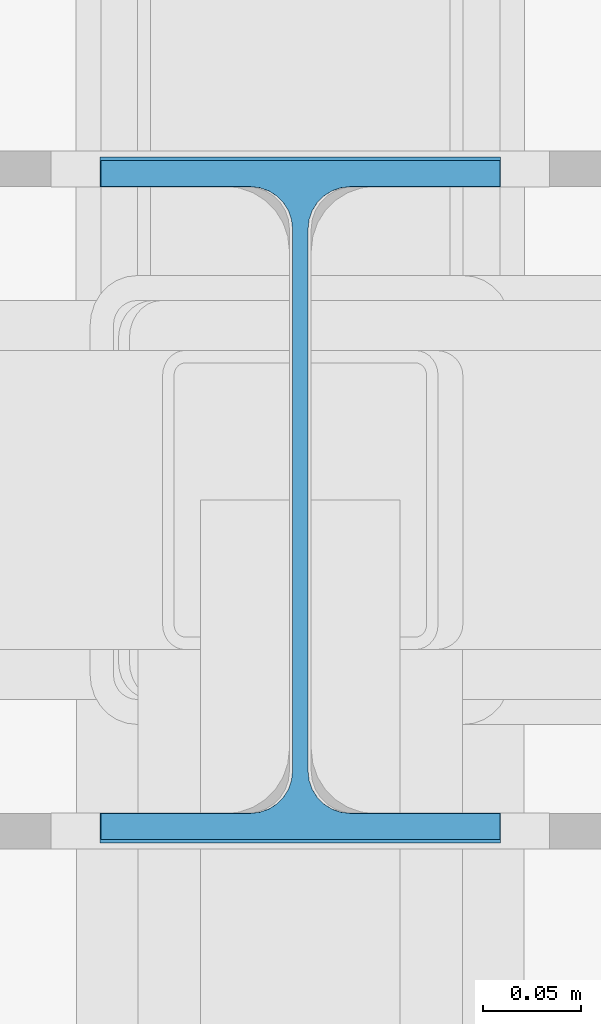
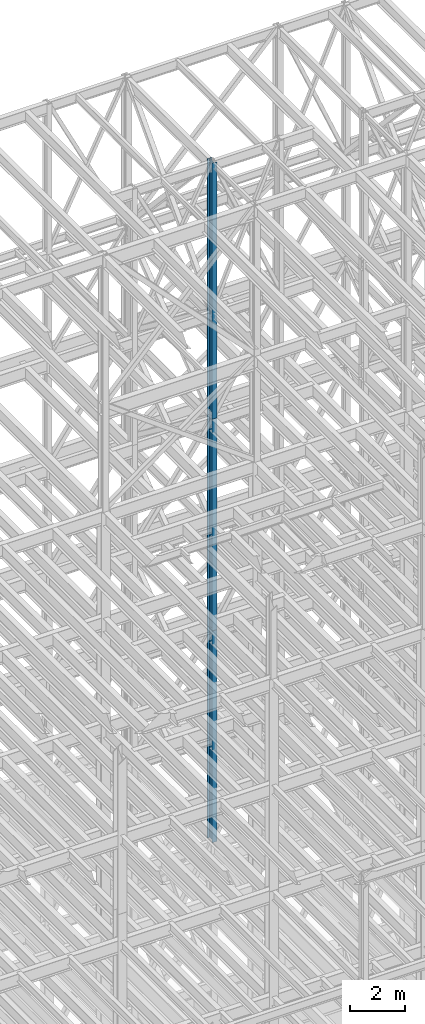
# One storey, part 44 of 150: 3 columns.
"""IFC2X3 building model written with IfcOpenShell, lengths in millimetres."""

import ifcopenshell
import ifcopenshell.guid

model = None  # the IFC model being written
_history = None  # IfcOwnerHistory: only IFC2X3 demands one
_inside = {}  # id of a spatial element -> (the spatial element, [elements in it])
_under = {}  # id of a project, library or spatial element -> (it, [spatial elements below it])
_declared = {}  # id of a project -> (the project, [libraries it declares])
_typed = {}  # id of a type object -> (the type object, [elements of that type])
_made_of = {}  # id of a material, layer set ... -> (it, [elements and type objects made of it])


def new_model(schema):
    """Start an empty IFC model of exactly this schema.

    Asked for "IFC4X3", IfcOpenShell would pick the latest addendum, in which some entities
    have other attributes; the version numbers below select the first issue.
    IFC2X3 requires an IfcOwnerHistory on every rooted entity: one is made here for all.
    """
    global model, _history
    if schema == "IFC4X3":
        model = ifcopenshell.file(schema_version=(4, 3, 0, 0))
    else:
        model = ifcopenshell.file(schema=schema)
    _inside.clear()
    _under.clear()
    _declared.clear()
    _typed.clear()
    _made_of.clear()
    _history = None
    if model.schema == "IFC2X3":
        org = make("IfcOrganization", Name="unknown")
        user = make(
            "IfcPersonAndOrganization",
            ThePerson=make("IfcPerson", FamilyName="unknown"),
            TheOrganization=org,
        )
        app = make(
            "IfcApplication",
            ApplicationDeveloper=org,
            Version="unknown",
            ApplicationFullName="unknown",
            ApplicationIdentifier="unknown",
        )
        _history = make(
            "IfcOwnerHistory",
            OwningUser=user,
            OwningApplication=app,
            ChangeAction="ADDED",
            CreationDate=0,
        )
    return model


def make(cls, **values):
    """One entity of the class cls with the attributes given. An attribute that is None is left unset."""
    return model.create_entity(
        cls, **{name: value for name, value in values.items() if value is not None}
    )


def rooted(cls, **values):
    """An entity with a GlobalId (a new one), such as an element, a storey or a relation."""
    return make(cls, GlobalId=ifcopenshell.guid.new(), OwnerHistory=_history, **values)


def si_unit(unit_type, name, prefix=None):
    """IfcSIUnit, for example si_unit("LENGTHUNIT", "METRE", prefix="MILLI")."""
    return make("IfcSIUnit", UnitType=unit_type, Prefix=prefix, Name=name)


def assignment(units):
    """IfcUnitAssignment: the units of a project."""
    return None if units is None else make("IfcUnitAssignment", Units=units)


def point(xyz):
    """IfcCartesianPoint."""
    return None if xyz is None else make("IfcCartesianPoint", Coordinates=xyz)


def direction(xyz):
    """IfcDirection."""
    return None if xyz is None else make("IfcDirection", DirectionRatios=xyz)


def frame(location, z_axis=None, x_axis=None):
    """IfcAxis2Placement3D, a coordinate frame: its origin and axes. An axis left out is left unset."""
    return make(
        "IfcAxis2Placement3D",
        Location=point(location),
        Axis=direction(z_axis),
        RefDirection=direction(x_axis),
    )


def frame_2d(location, x_axis=None):
    """IfcAxis2Placement2D, a coordinate frame in the plane: its origin and x axis."""
    return make(
        "IfcAxis2Placement2D", Location=point(location), RefDirection=direction(x_axis)
    )


def origin_with_axes():
    """The frame at (0, 0, 0) with the z axis (0, 0, 1) and the x axis (1, 0, 0) written out."""
    return frame((0.0, 0.0, 0.0), z_axis=(0.0, 0.0, 1.0), x_axis=(1.0, 0.0, 0.0))


def origin_2d_with_axis():
    """The frame at (0, 0) in the plane with the x axis (1, 0) written out."""
    return frame_2d((0.0, 0.0), x_axis=(1.0, 0.0))


def place(relative_to, where):
    """IfcLocalPlacement: puts the frame where relative to a parent placement (None: the world)."""
    return make(
        "IfcLocalPlacement", PlacementRelTo=relative_to, RelativePlacement=where
    )


def context(
    kind, dimensions, precision=None, world=None, true_north=None, identifier=None
):
    """IfcGeometricRepresentationContext, for example the 3D "Model" context."""
    return make(
        "IfcGeometricRepresentationContext",
        ContextIdentifier=identifier,
        ContextType=kind,
        CoordinateSpaceDimension=dimensions,
        Precision=precision,
        WorldCoordinateSystem=world,
        TrueNorth=true_north,
    )


def subcontext(parent, identifier, kind, view, scale=None):
    """IfcGeometricRepresentationSubContext, for example "Body" below "Model"."""
    return make(
        "IfcGeometricRepresentationSubContext",
        ContextIdentifier=identifier,
        ContextType=kind,
        ParentContext=parent,
        TargetScale=scale,
        TargetView=view,
    )


def project(units=None, contexts=None):
    """IfcProject with its units and contexts."""
    return rooted(
        "IfcProject",
        Name="project",
        RepresentationContexts=contexts,
        UnitsInContext=assignment(units),
    )


def spatial(cls, under=None, at=None, **own):
    """A site, building, storey or space (cls), placed at a placement, below another one or the project."""
    s = rooted(cls, ObjectPlacement=at, **own)
    if under is not None:
        _under.setdefault(under.id(), (under, []))[1].append(s)
    return s


def profile(cls, at=None, kind="AREA", **sizes):
    """A parametric profile (cls). Its sizes go by their IFC names, for example OverallWidth=200.0."""
    return make(cls, ProfileType=kind, Position=at, **sizes)


def i_section(**sizes):
    """IfcIShapeProfileDef."""
    return profile("IfcIShapeProfileDef", **sizes)


def extrude(swept, where, along, depth):
    """IfcExtrudedAreaSolid: the profile swept, set in the frame where, extruded along a direction by depth."""
    return make(
        "IfcExtrudedAreaSolid",
        SweptArea=swept,
        Position=where,
        ExtrudedDirection=direction(along),
        Depth=depth,
    )


def shape(context_of_items, identifier, shape_type, items):
    """IfcShapeRepresentation: the items that make up one representation, for example the "Body"."""
    return make(
        "IfcShapeRepresentation",
        ContextOfItems=context_of_items,
        RepresentationIdentifier=identifier,
        RepresentationType=shape_type,
        Items=items,
    )


def material(Name=None, Category=None):
    """IfcMaterial."""
    return make("IfcMaterial", Name=Name, Category=Category)


def made_of(thing, what):
    """Note that an element or type object is made of a material, layer set ...; save() writes the relation."""
    if what is not None:
        _made_of.setdefault(what.id(), (what, []))[1].append(thing)
    return thing


def type_object(cls, material=None, **own):
    """A type object (cls), such as IfcWallType, which elements share."""
    return made_of(rooted(cls, **own), material)


def element(
    cls,
    number,
    at=None,
    inside=None,
    cuts=None,
    type_object=None,
    material=None,
    context=None,
    identifier="Body",
    shape_type=None,
    held_by="IfcProductDefinitionShape",
    body=None,
    shapes=None,
    **own,
):
    """One element of the class cls, such as IfcWall. Its Tag is "e" and its number.

    at: its placement. inside: the storey or other place that contains it. cuts: it is an
    opening in that element (IfcRelVoidsElement). A single representation is given by context,
    identifier, shape_type and body (its items); several are given by shapes. held_by: the class
    of the entity that holds the representations. save() writes the other relations.
    """
    e = rooted(cls, Tag="e%d" % number, ObjectPlacement=at, **own)
    if body is not None:
        shapes = [shape(context, identifier, shape_type, body)]
    if shapes is not None:
        e.Representation = make(held_by, Representations=shapes)
    if inside is not None:
        _inside.setdefault(inside.id(), (inside, []))[1].append(e)
    if cuts is not None:
        rooted(
            "IfcRelVoidsElement", RelatingBuildingElement=cuts, RelatedOpeningElement=e
        )
    if type_object is not None:
        _typed.setdefault(type_object.id(), (type_object, []))[1].append(e)
    return made_of(e, material)


def aggregate(whole, parts):
    """IfcRelAggregates: a whole, such as a stair, and the parts it consists of."""
    return rooted("IfcRelAggregates", RelatingObject=whole, RelatedObjects=parts)


def save(model, path):
    """Write the relations noted so far, then the file.

    IfcRelAggregates (storeys below a building ...), IfcRelContainedInSpatialStructure (elements
    in a storey), IfcRelDefinesByType, IfcRelAssociatesMaterial and IfcRelDeclares: one each for
    every whole, place, type object, material and project.
    """
    for whole, parts in _under.values():
        aggregate(whole, parts)
    for where, things in _inside.values():
        rooted(
            "IfcRelContainedInSpatialStructure",
            RelatedElements=things,
            RelatingStructure=where,
        )
    for kind, things in _typed.values():
        rooted("IfcRelDefinesByType", RelatedObjects=things, RelatingType=kind)
    for what, things in _made_of.values():
        rooted("IfcRelAssociatesMaterial", RelatedObjects=things, RelatingMaterial=what)
    for by, libraries in _declared.values():
        rooted("IfcRelDeclares", RelatingContext=by, RelatedDefinitions=libraries)
    model.write(path)


model = new_model("IFC2X3")

# Units and contexts
model_context = context("Model", 3, precision=1e-05, world=origin_with_axes())
body_context = subcontext(model_context, "Body", "Model", "MODEL_VIEW")
ifc_project = project(units=[si_unit("LENGTHUNIT", "METRE", prefix="MILLI"), si_unit("AREAUNIT", "SQUARE_METRE"), si_unit("VOLUMEUNIT", "CUBIC_METRE"), si_unit("MASSUNIT", "GRAM", prefix="KILO"), si_unit("TIMEUNIT", "SECOND"), si_unit("PLANEANGLEUNIT", "RADIAN"), si_unit("SOLIDANGLEUNIT", "STERADIAN"), si_unit("THERMODYNAMICTEMPERATUREUNIT", "DEGREE_CELSIUS"), si_unit("LUMINOUSINTENSITYUNIT", "LUMEN")], contexts=[model_context])

# Site, building, storey
site_placement = place(None, origin_with_axes())
site = spatial("IfcSite", under=ifc_project, at=site_placement, CompositionType="ELEMENT")
building_placement = place(site_placement, origin_with_axes())
building = spatial("IfcBuilding", under=site, at=building_placement, Name="Undefined", CompositionType="ELEMENT")
storey_placement = place(building_placement, origin_with_axes())
storey = spatial("IfcBuildingStorey", under=building, at=storey_placement, Name="Undefined", CompositionType="ELEMENT", Elevation=0.0)

# Columns
ifc_material = material(Name="STEEL/A992")
column_type_1 = type_object("IfcColumnType", Name="W14X43", PredefinedType="NOTDEFINED")
column_1_placement = place(storey_placement, frame((56591.2, 25628.6, 54483.0), z_axis=(0.0, 0.0, 1.0), x_axis=(1.0, 0.0, 0.0)))
element("IfcColumn", 1, at=column_1_placement, inside=storey, type_object=column_type_1, material=ifc_material, Name="COLUMN", ObjectType="W14X43", context=body_context, shape_type="SweptSolid", body=[
    extrude(i_section(OverallWidth=203.2, OverallDepth=346.075, WebThickness=7.9375, FlangeThickness=13.462, FilletRadius=21.4629, at=origin_2d_with_axis()), frame((0.0, 0.0, 11429.998857), z_axis=(0.0, 0.0, -1.0), x_axis=(-1.0, 0.0, 0.0)), (0.0, 0.0, 1.0), 11429.998857),
])
column_2_placement = place(storey_placement, frame((56591.2, 25628.6, 45034.2), z_axis=(0.0, 0.0, 1.0), x_axis=(1.0, 0.0, 0.0)))
element("IfcColumn", 2, at=column_2_placement, inside=storey, type_object=column_type_1, material=ifc_material, Name="COLUMN", ObjectType="W14X43", context=body_context, shape_type="SweptSolid", body=[
    extrude(i_section(OverallWidth=203.2, OverallDepth=346.075, WebThickness=7.9375, FlangeThickness=13.462, FilletRadius=21.4629, at=origin_2d_with_axis()), frame((0.0, 0.0, 9448.8), z_axis=(0.0, 0.0, -1.0), x_axis=(-1.0, 0.0, 0.0)), (0.0, 0.0, 1.0), 9448.8),
])
column_type_2 = type_object("IfcColumnType", Name="W14X48", PredefinedType="NOTDEFINED")
column_3_placement = place(storey_placement, frame((56591.2, 25628.6, 35585.4), z_axis=(0.0, 0.0, 1.0), x_axis=(1.0, 0.0, 0.0)))
element("IfcColumn", 3, at=column_3_placement, inside=storey, type_object=column_type_2, material=ifc_material, Name="COLUMN", ObjectType="W14X48", context=body_context, shape_type="SweptSolid", body=[
    extrude(i_section(OverallWidth=203.962, OverallDepth=349.25, WebThickness=7.9375, FlangeThickness=15.113, FilletRadius=21.3994, at=origin_2d_with_axis()), frame((0.0, 0.0, 9448.8), z_axis=(0.0, 0.0, -1.0), x_axis=(-1.0, 0.0, 0.0)), (0.0, 0.0, 1.0), 9448.8),
])

save(model, "model.ifc")
